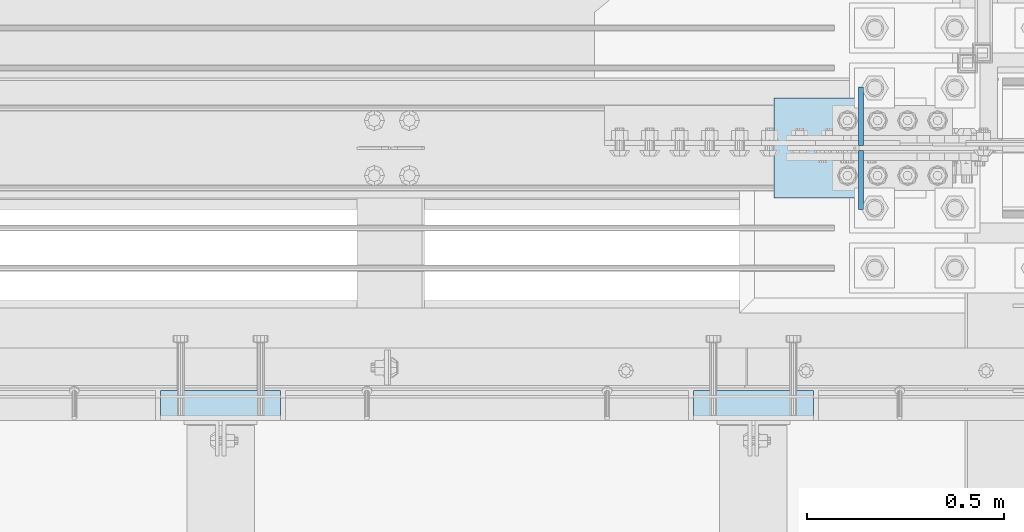
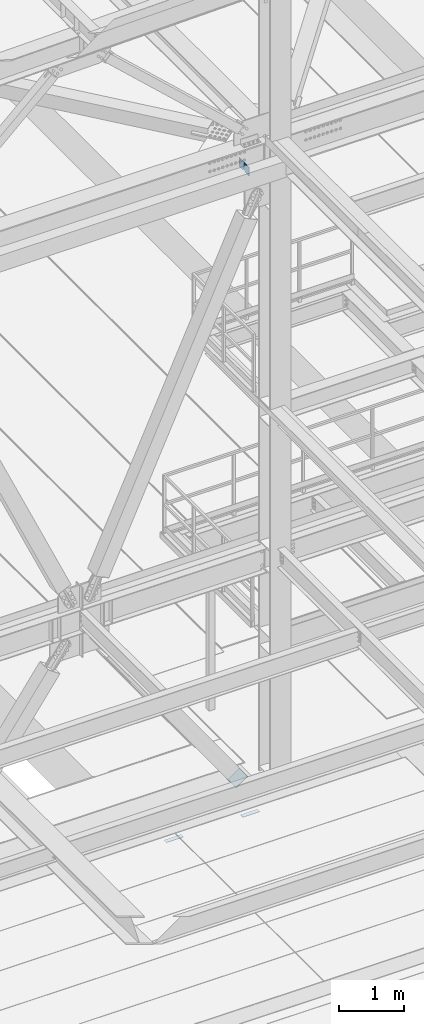
# One storey, part 3132 of 3843: 5 plates, 4 elements without a shape of their own.
"""IFC2X3 building model written with IfcOpenShell, lengths in millimetres."""

from ifc_helpers import new_model, si_unit, frame, origin_with_axes, place, context, subcontext, project, spatial, faceted_brep, material, type_object, element, aggregate, save


model = new_model("IFC2X3")

# Units and contexts
model_context = context("Model", 3, precision=1e-05, world=origin_with_axes())
body_context = subcontext(model_context, "Body", "Model", "MODEL_VIEW")
ifc_project = project(units=[si_unit("LENGTHUNIT", "METRE", prefix="MILLI"), si_unit("AREAUNIT", "SQUARE_METRE"), si_unit("VOLUMEUNIT", "CUBIC_METRE"), si_unit("MASSUNIT", "GRAM", prefix="KILO"), si_unit("TIMEUNIT", "SECOND"), si_unit("PLANEANGLEUNIT", "RADIAN"), si_unit("SOLIDANGLEUNIT", "STERADIAN"), si_unit("THERMODYNAMICTEMPERATUREUNIT", "DEGREE_CELSIUS"), si_unit("LUMINOUSINTENSITYUNIT", "LUMEN")], contexts=[model_context])

# Site, building, storey
site_placement = place(None, origin_with_axes())
site = spatial("IfcSite", under=ifc_project, at=site_placement, CompositionType="ELEMENT")
building_placement = place(site_placement, origin_with_axes())
building = spatial("IfcBuilding", under=site, at=building_placement, Name="Undefined", CompositionType="ELEMENT")
storey_placement = place(building_placement, origin_with_axes())
storey = spatial("IfcBuildingStorey", under=building, at=storey_placement, Name="Undefined", CompositionType="ELEMENT", Elevation=0.0)

# Assembly, plate
assembly_1_placement = place(storey_placement, origin_with_axes())
assembly_1 = element("IfcElementAssembly", 1, at=assembly_1_placement, inside=storey, Name="EMBED PLATE", AssemblyPlace="NOTDEFINED", PredefinedType="RIGID_FRAME")
ifc_material_1 = material(Name="STEEL/A36")
plate_type_1 = type_object("IfcPlateType", PredefinedType="NOTDEFINED")
plate_1_placement = place(assembly_1_placement, frame((46980.475, 24923.7499969483, 30400.625), z_axis=(-1.0, 0.0, 0.0), x_axis=(0.0, 1.0, 0.0)))
plate_1 = element("IfcPlate", 2, at=plate_1_placement, type_object=plate_type_1, material=ifc_material_1, Name="PLATE", context=body_context, shape_type="Brep", body=[
    faceted_brep([(0.0, -3.17499999999927, 0.0), (0.0, -3.17499999999927, 304.800000000003), (0.0, 3.17499999999927, 304.800000000003), (0.0, 3.17499999999927, 0.0), (76.1999999999971, -3.17499999999927, 304.799999999996), (76.1999999999971, 3.17499999999927, 304.799999999996), (76.1999999999971, -3.17499999999927, 0.0), (76.1999999999971, 3.17499999999927, 0.0)], [[[0, 1, 2, 3]], [[1, 4, 5, 2]], [[4, 6, 7, 5]], [[6, 0, 3, 7]], [[5, 7, 3, 2]], [[6, 4, 1, 0]]]),
])
aggregate(assembly_1, [plate_1])

assembly_2_placement = place(storey_placement, origin_with_axes())
assembly_2 = element("IfcElementAssembly", 3, at=assembly_2_placement, inside=storey, Name="EMBED PLATE", AssemblyPlace="NOTDEFINED", PredefinedType="RIGID_FRAME")
plate_2_placement = place(assembly_2_placement, frame((48333.025, 24923.7499969483, 30400.625), z_axis=(-1.0, 0.0, 0.0), x_axis=(0.0, 1.0, 0.0)))
plate_2 = element("IfcPlate", 4, at=plate_2_placement, type_object=plate_type_1, material=ifc_material_1, Name="PLATE", context=body_context, shape_type="Brep", body=[
    faceted_brep([(0.0, -3.17499999999927, 0.0), (0.0, -3.17499999999927, 304.800000000003), (0.0, 3.17499999999927, 304.800000000003), (0.0, 3.17499999999927, 0.0), (76.1999999999971, -3.17499999999927, 304.799999999996), (76.1999999999971, 3.17499999999927, 304.799999999996), (76.1999999999971, -3.17499999999927, 0.0), (76.1999999999971, 3.17499999999927, 0.0)], [[[0, 1, 2, 3]], [[1, 4, 5, 2]], [[4, 6, 7, 5]], [[6, 0, 3, 7]], [[5, 7, 3, 2]], [[6, 4, 1, 0]]]),
])
aggregate(assembly_2, [plate_2])

# Assembly, plates
assembly_3_placement = place(storey_placement, origin_with_axes())
assembly_3 = element("IfcElementAssembly", 5, at=assembly_3_placement, inside=storey, Name="BEAM", AssemblyPlace="NOTDEFINED", PredefinedType="RIGID_FRAME")
ifc_material_2 = material(Name="STEEL/A572-50")
plate_type_2 = type_object("IfcPlateType", PredefinedType="NOTDEFINED")
plate_3_placement = place(assembly_3_placement, frame((48453.5536446762, 25609.55, 42110.025), z_axis=(0.0, 0.0, -1.0), x_axis=(0.0, -1.0, 0.0)))
plate_3 = element("IfcPlate", 6, at=plate_3_placement, type_object=plate_type_2, material=ifc_material_2, Name="PLATE", context=body_context, shape_type="Brep", body=[
    faceted_brep([(0.0, -6.3499999046162, 0.0), (0.0, -6.35000000000582, 131.762499999997), (0.0, 6.35000000000582, 131.762499999997), (7.27595761418343e-12, 6.3499999046162, 0.0), (31.75, -6.35000000000582, 163.512499999997), (31.75, 6.35000000000582, 163.512499999997), (149.224999999991, -6.35000000000582, 163.512499999997), (149.224999999991, 6.35000000000582, 163.512499999997), (149.224999999991, -6.35000000000582, 0.0), (149.224999999991, 6.35000000000582, 0.0)], [[[0, 1, 2, 3]], [[1, 4, 5, 2]], [[4, 6, 7, 5]], [[6, 8, 9, 7]], [[8, 0, 3, 9]], [[5, 7, 9, 3, 2]], [[8, 6, 4, 1, 0]]]),
])
plate_4_placement = place(assembly_3_placement, frame((48453.5536446762, 25771.475, 42110.025), z_axis=(0.0, 0.0, -1.0), x_axis=(0.0, -1.0, 0.0)))
plate_4 = element("IfcPlate", 7, at=plate_4_placement, type_object=plate_type_2, material=ifc_material_2, Name="PLATE", context=body_context, shape_type="Brep", body=[
    faceted_brep([(0.0, -6.3499999046162, 0.0), (0.0, -6.34999999999854, 163.512499999997), (0.0, 6.34999999999854, 163.512499999997), (7.27595761418343e-12, 6.3499999046162, 0.0), (117.474999999991, -6.34999999999854, 163.512499999997), (117.474999999991, 6.34999999999854, 163.512499999997), (149.224999999991, -6.34999999999854, 131.762499999997), (149.224999999991, 6.34999999999854, 131.762499999997), (149.224999999991, -6.35000000000582, 0.0), (149.224999999991, 6.35000000000582, 0.0)], [[[0, 1, 2, 3]], [[1, 4, 5, 2]], [[4, 6, 7, 5]], [[6, 8, 9, 7]], [[8, 0, 3, 9]], [[5, 7, 9, 3, 2]], [[8, 6, 4, 1, 0]]]),
])
aggregate(assembly_3, [plate_3, plate_4])

# Assembly, plate
assembly_4_placement = place(storey_placement, origin_with_axes())
assembly_4 = element("IfcElementAssembly", 8, at=assembly_4_placement, inside=storey, Name="Plate", AssemblyPlace="NOTDEFINED", PredefinedType="RIGID_FRAME")
plate_type_3 = type_object("IfcPlateType", PredefinedType="NOTDEFINED")
plate_5_placement = place(assembly_4_placement, frame((48234.742593958, 25742.9, 30537.165025148), z_axis=(0.816439959974278, 0.0, 0.577430334981805), x_axis=(0.0, -1.0, 0.0)))
plate_5 = element("IfcPlate", 9, at=plate_5_placement, type_object=plate_type_3, material=ifc_material_1, Name="Plate", context=body_context, shape_type="Brep", body=[
    faceted_brep([(0.0, -3.17499999999927, 0.0), (0.0, -3.17499999965185, 254.000000005151), (0.0, 3.17500000035216, 254.000000005166), (0.0, 3.17499999999927, 0.0), (254.0, -3.17499999965185, 254.000000005151), (254.0, 3.17500000035216, 254.000000005166), (254.0, -3.17500000000291, 0.0), (254.0, 3.17499999999927, 1.45519152283669e-11)], [[[0, 1, 2, 3]], [[1, 4, 5, 2]], [[4, 6, 7, 5]], [[6, 0, 3, 7]], [[5, 7, 3, 2]], [[6, 4, 1, 0]]]),
])
aggregate(assembly_4, [plate_5])

save(model, "model.ifc")
